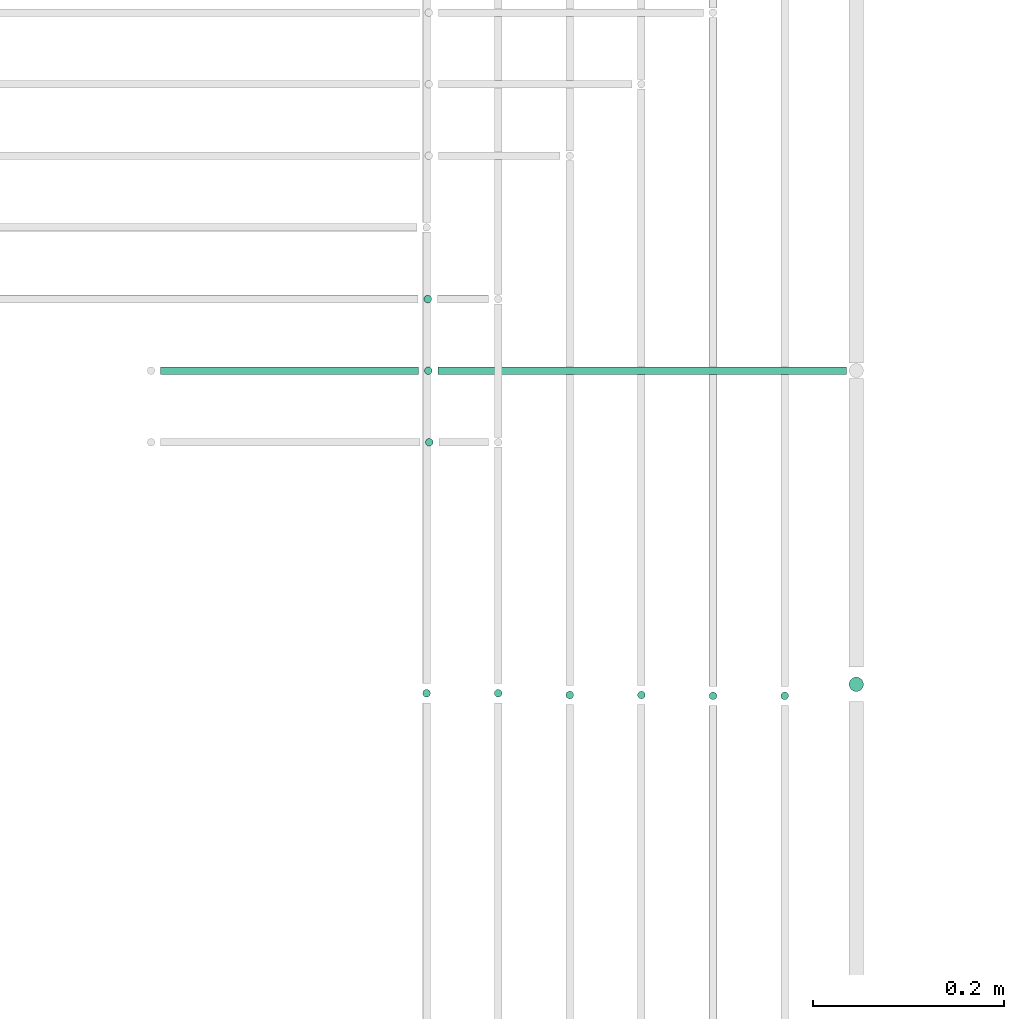
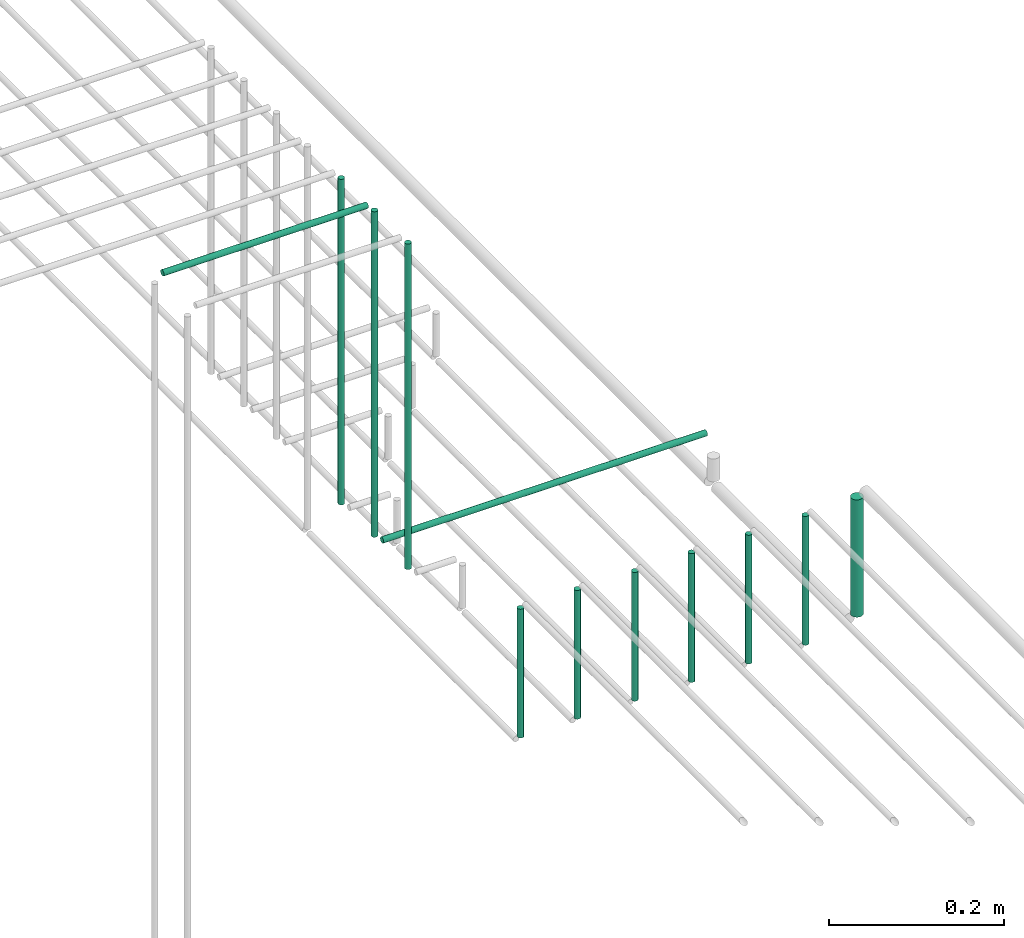
# One storey, part 49 of 89: 12 flow segments.
"""IFC2X3 building model written with IfcOpenShell, lengths in millimetres."""

from ifc_helpers import new_model, entity, si_unit, converted_unit, derived_unit, direction, frame, frame_2d, origin, origin_2d_with_axis, place, context, subcontext, project, spatial, circle, extrude, type_object, element, save


model = new_model("IFC2X3")

# Units and contexts
model_context = context("Model", 3, precision=0.01, world=origin(), true_north=direction((6.12303176911189e-17, 1.0)))
body_context = subcontext(model_context, "Body", "Model", "MODEL_VIEW")
ifc_project = project(units=[si_unit("LENGTHUNIT", "METRE", prefix="MILLI"), si_unit("AREAUNIT", "SQUARE_METRE"), si_unit("VOLUMEUNIT", "CUBIC_METRE"), converted_unit("PLANEANGLEUNIT", "DEGREE", entity("IfcRatioMeasure", 0.0174532925199433), si_unit("PLANEANGLEUNIT", "RADIAN"), dimensions=[0, 0, 0, 0, 0, 0, 0]), si_unit("MASSUNIT", "GRAM", prefix="KILO"), derived_unit("MASSDENSITYUNIT", [(si_unit("MASSUNIT", "GRAM", prefix="KILO"), 1), (si_unit("LENGTHUNIT", "METRE"), -3)]), derived_unit("MOMENTOFINERTIAUNIT", [(si_unit("LENGTHUNIT", "METRE"), 4)]), si_unit("TIMEUNIT", "SECOND"), si_unit("FREQUENCYUNIT", "HERTZ"), si_unit("THERMODYNAMICTEMPERATUREUNIT", "DEGREE_CELSIUS"), derived_unit("THERMALTRANSMITTANCEUNIT", [(si_unit("MASSUNIT", "GRAM", prefix="KILO"), 1), (si_unit("THERMODYNAMICTEMPERATUREUNIT", "KELVIN"), -1), (si_unit("TIMEUNIT", "SECOND"), -3)]), derived_unit("VOLUMETRICFLOWRATEUNIT", [(si_unit("LENGTHUNIT", "METRE"), 3), (si_unit("TIMEUNIT", "SECOND"), -1)]), derived_unit("MASSFLOWRATEUNIT", [(si_unit("MASSUNIT", "GRAM", prefix="KILO"), 1), (si_unit("TIMEUNIT", "SECOND"), -1)]), derived_unit("ROTATIONALFREQUENCYUNIT", [(si_unit("TIMEUNIT", "SECOND"), -1)]), si_unit("ELECTRICCURRENTUNIT", "AMPERE"), si_unit("ELECTRICVOLTAGEUNIT", "VOLT"), si_unit("POWERUNIT", "WATT"), si_unit("FORCEUNIT", "NEWTON", prefix="KILO"), si_unit("ILLUMINANCEUNIT", "LUX"), si_unit("LUMINOUSFLUXUNIT", "LUMEN"), si_unit("LUMINOUSINTENSITYUNIT", "CANDELA"), derived_unit("USERDEFINED", [(si_unit("MASSUNIT", "GRAM", prefix="KILO"), -1), (si_unit("LENGTHUNIT", "METRE"), -2), (si_unit("TIMEUNIT", "SECOND"), 3), (si_unit("LUMINOUSFLUXUNIT", "LUMEN"), 1)]), derived_unit("LINEARVELOCITYUNIT", [(si_unit("LENGTHUNIT", "METRE"), 1), (si_unit("TIMEUNIT", "SECOND"), -1)]), si_unit("PRESSUREUNIT", "PASCAL"), derived_unit("USERDEFINED", [(si_unit("LENGTHUNIT", "METRE"), -2), (si_unit("MASSUNIT", "GRAM", prefix="KILO"), 1), (si_unit("TIMEUNIT", "SECOND"), -2)]), derived_unit("LINEARFORCEUNIT", [(si_unit("MASSUNIT", "GRAM", prefix="KILO"), 1), (si_unit("LENGTHUNIT", "METRE"), 1), (si_unit("TIMEUNIT", "SECOND"), -2), (si_unit("LENGTHUNIT", "METRE"), -1)]), derived_unit("PLANARFORCEUNIT", [(si_unit("MASSUNIT", "GRAM", prefix="KILO"), 1), (si_unit("LENGTHUNIT", "METRE"), 1), (si_unit("TIMEUNIT", "SECOND"), -2), (si_unit("LENGTHUNIT", "METRE"), -2)])], contexts=[model_context])

# Site, building, storey
site_placement = place(None, frame((0.0, -0.00077364408347762, 0.0)))
site = spatial("IfcSite", under=ifc_project, at=site_placement, CompositionType="ELEMENT")
building_placement = place(site_placement, origin())
building = spatial("IfcBuilding", under=site, at=building_placement, CompositionType="ELEMENT")
storey_placement = place(building_placement, frame((0.0, 0.0, 24000.0)))
storey = spatial("IfcBuildingStorey", under=building, at=storey_placement, CompositionType="ELEMENT", Elevation=24000.0)

# Flow segments
pipe_segment_type = type_object("IfcPipeSegmentType", PredefinedType="NOTDEFINED")
flow_segment_1_placement = place(storey_placement, frame((67217.2968748086, 4982.64530556803, 2685.0)))
element("IfcFlowSegment", 1, at=flow_segment_1_placement, inside=storey, type_object=pipe_segment_type, context=body_context, shape_type="SweptSolid", body=[
    extrude(circle(Radius=4.0, at=frame_2d((0.0, -1.08286712929839e-12), x_axis=(1.0, 0.0))), frame((5.59527223591499, 5.59527223591499, 0.0), z_axis=(0.0, 0.0, 1.0), x_axis=(-1.0, 0.0, 0.0)), (0.0, 0.0, 1.0), 455.000000000022),
])
flow_segment_2_placement = place(storey_placement, frame((67231.8152421112, 5057.64530556804, 2669.40472776406)))
element("IfcFlowSegment", 2, at=flow_segment_2_placement, inside=storey, type_object=pipe_segment_type, context=body_context, shape_type="SweptSolid", body=[
    extrude(circle(Radius=4.0, at=origin_2d_with_axis()), frame((0.0, 5.59527223591716, 5.59527223591499), z_axis=(1.0, 0.0, 0.0), x_axis=(0.0, -1.0, 0.0)), (0.0, 0.0, 1.0), 428.185026443704),
])
flow_segment_3_placement = place(storey_placement, frame((66941.4633506707, 5057.64530556803, 3144.40472776409)))
element("IfcFlowSegment", 3, at=flow_segment_3_placement, inside=storey, type_object=pipe_segment_type, context=body_context, shape_type="SweptSolid", body=[
    extrude(circle(Radius=4.0, at=frame_2d((2.16573425859679e-12, 0.0), x_axis=(1.0, 0.0))), frame((0.0, 5.59527223591716, 5.59527223591499), z_axis=(1.0, 0.0, 0.0), x_axis=(0.0, 1.0, 0.0)), (0.0, 0.0, 1.0), 270.351891440449),
])
flow_segment_4_placement = place(storey_placement, frame((67216.2199698753, 5057.64530556804, 2685.0)))
element("IfcFlowSegment", 4, at=flow_segment_4_placement, inside=storey, type_object=pipe_segment_type, context=body_context, shape_type="SweptSolid", body=[
    extrude(circle(Radius=4.0, at=origin_2d_with_axis()), frame((5.59527223591499, 5.59527223591607, 0.0), z_axis=(0.0, 0.0, 1.0), x_axis=(-1.0, 0.0, 0.0)), (0.0, 0.0, 1.0), 455.000000000022),
])
flow_segment_5_placement = place(storey_placement, frame((67215.6866543042, 5132.64530556803, 2685.0)))
element("IfcFlowSegment", 5, at=flow_segment_5_placement, inside=storey, type_object=pipe_segment_type, context=body_context, shape_type="SweptSolid", body=[
    extrude(circle(Radius=4.0, at=origin_2d_with_axis()), frame((5.59527223591499, 5.59527223591607, 0.0), z_axis=(0.0, 0.0, 1.0), x_axis=(-1.0, 0.0, 0.0)), (0.0, 0.0, 1.0), 455.000000000048),
])
flow_segment_6_placement = place(storey_placement, frame((67214.4049963189, 4719.83051626478, 2610.0)))
element("IfcFlowSegment", 6, at=flow_segment_6_placement, inside=storey, type_object=pipe_segment_type, context=body_context, shape_type="SweptSolid", body=[
    extrude(circle(Radius=4.0, at=origin_2d_with_axis()), frame((5.59527223591499, 5.59527223591607, 0.0)), (0.0, 0.0, 1.0), 180.000000000015),
])
flow_segment_7_placement = place(storey_placement, frame((67289.4049963189, 4719.83051626479, 2610.0)))
element("IfcFlowSegment", 7, at=flow_segment_7_placement, inside=storey, type_object=pipe_segment_type, context=body_context, shape_type="SweptSolid", body=[
    extrude(circle(Radius=4.0, at=origin_2d_with_axis()), frame((5.59527223591499, 5.59527223591607, 0.0)), (0.0, 0.0, 1.0), 180.000000000007),
])
for number, where in (
    (8, (67364.4049963189, 4718.01052185797, 2610.0)),
    (9, (67439.4049963189, 4718.01052185797, 2610.0)),
    (10, (67514.4049963189, 4717.10052465455, 2610.0)),
    (11, (67589.4049963189, 4717.10052465456, 2610.0)),
):
    element("IfcFlowSegment", number, at=place(storey_placement, frame(where)), inside=storey, type_object=pipe_segment_type, context=body_context, shape_type="SweptSolid", body=[
        extrude(circle(Radius=4.0, at=origin_2d_with_axis()), frame((5.59527223591499, 5.59527223591607, 0.0)), (0.0, 0.0, 1.0), 180.000000000015),
    ])
flow_segment_8_placement = place(storey_placement, frame((67660.9049963189, 4725.69052745111, 2618.0)))
element("IfcFlowSegment", 12, at=flow_segment_8_placement, inside=storey, type_object=pipe_segment_type, context=body_context, shape_type="SweptSolid", body=[
    extrude(circle(Radius=7.5, at=origin_2d_with_axis()), frame((9.09527223591419, 9.09527223591582, 0.0), z_axis=(0.0, 0.0, 1.0), x_axis=(-1.0, 0.0, 0.0)), (0.0, 0.0, 1.0), 164.000000000015),
])

save(model, "model.ifc")
